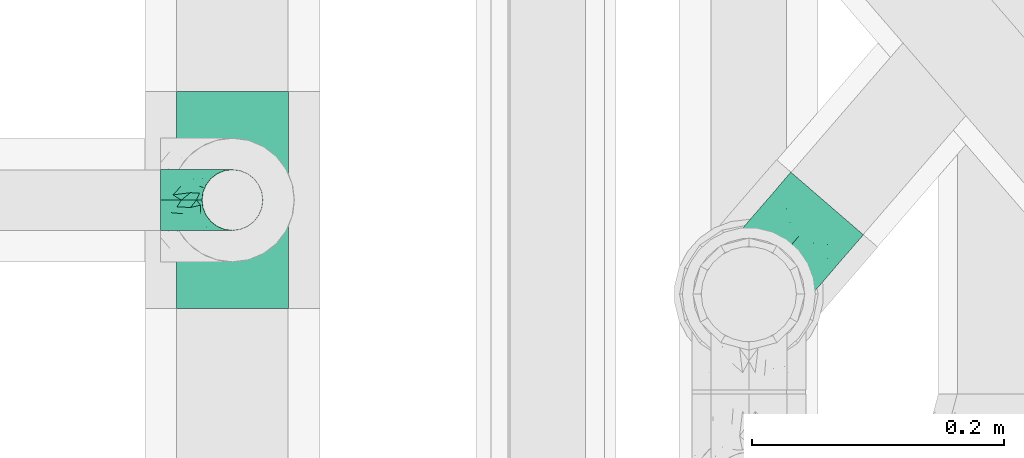
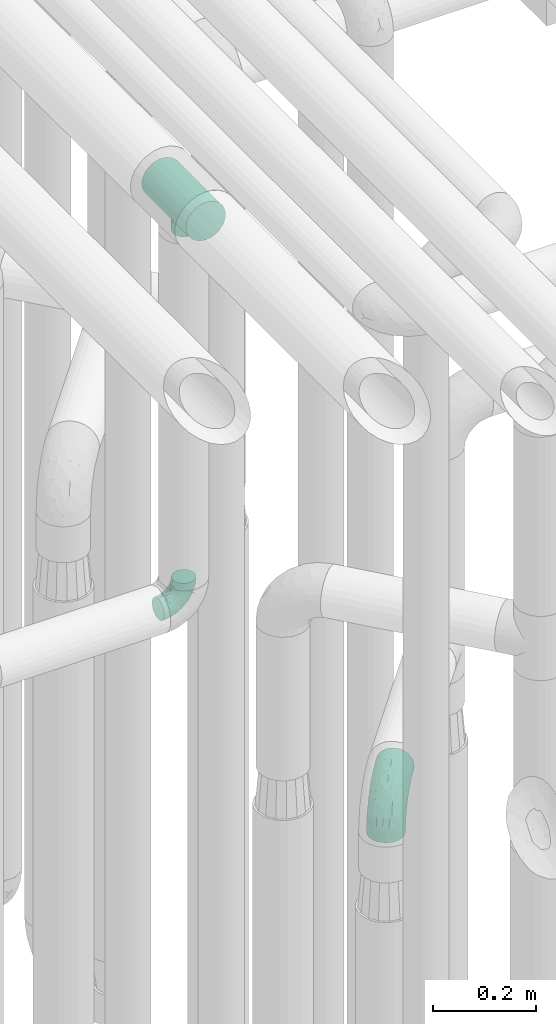
# One storey, part 607 of 827: 3 flow fittings.
"""IFC2X3 building model written with IfcOpenShell, lengths in millimetres."""

import ifcopenshell
import ifcopenshell.guid

model = None  # the IFC model being written
_history = None  # IfcOwnerHistory: only IFC2X3 demands one
_inside = {}  # id of a spatial element -> (the spatial element, [elements in it])
_under = {}  # id of a project, library or spatial element -> (it, [spatial elements below it])
_declared = {}  # id of a project -> (the project, [libraries it declares])
_typed = {}  # id of a type object -> (the type object, [elements of that type])
_made_of = {}  # id of a material, layer set ... -> (it, [elements and type objects made of it])


def new_model(schema):
    """Start an empty IFC model of exactly this schema.

    Asked for "IFC4X3", IfcOpenShell would pick the latest addendum, in which some entities
    have other attributes; the version numbers below select the first issue.
    IFC2X3 requires an IfcOwnerHistory on every rooted entity: one is made here for all.
    """
    global model, _history
    if schema == "IFC4X3":
        model = ifcopenshell.file(schema_version=(4, 3, 0, 0))
    else:
        model = ifcopenshell.file(schema=schema)
    _inside.clear()
    _under.clear()
    _declared.clear()
    _typed.clear()
    _made_of.clear()
    _history = None
    if model.schema == "IFC2X3":
        org = make("IfcOrganization", Name="unknown")
        user = make(
            "IfcPersonAndOrganization",
            ThePerson=make("IfcPerson", FamilyName="unknown"),
            TheOrganization=org,
        )
        app = make(
            "IfcApplication",
            ApplicationDeveloper=org,
            Version="unknown",
            ApplicationFullName="unknown",
            ApplicationIdentifier="unknown",
        )
        _history = make(
            "IfcOwnerHistory",
            OwningUser=user,
            OwningApplication=app,
            ChangeAction="ADDED",
            CreationDate=0,
        )
    return model


def make(cls, **values):
    """One entity of the class cls with the attributes given. An attribute that is None is left unset."""
    return model.create_entity(
        cls, **{name: value for name, value in values.items() if value is not None}
    )


def entity(cls, *values):
    """Any entity or typed value of the class cls, its attributes in the order of the schema. None: left unset."""
    e = model.create_entity(cls)
    for i, value in enumerate(values):
        if value is not None:
            e[i] = value
    return e


def rooted(cls, **values):
    """An entity with a GlobalId (a new one), such as an element, a storey or a relation."""
    return make(cls, GlobalId=ifcopenshell.guid.new(), OwnerHistory=_history, **values)


def si_unit(unit_type, name, prefix=None):
    """IfcSIUnit, for example si_unit("LENGTHUNIT", "METRE", prefix="MILLI")."""
    return make("IfcSIUnit", UnitType=unit_type, Prefix=prefix, Name=name)


def converted_unit(unit_type, name, factor, base, dimensions=None, offset=None):
    """IfcConversionBasedUnit, such as the inch: factor (a typed value) times the base unit."""
    return make(
        "IfcConversionBasedUnit"
        if offset is None
        else "IfcConversionBasedUnitWithOffset",
        ConversionOffset=offset,
        Dimensions=None
        if dimensions is None
        else entity("IfcDimensionalExponents", *dimensions),
        UnitType=unit_type,
        Name=name,
        ConversionFactor=make(
            "IfcMeasureWithUnit", ValueComponent=factor, UnitComponent=base
        ),
    )


def derived_unit(unit_type, elements):
    """IfcDerivedUnit: a product of units, each with its exponent."""
    return make(
        "IfcDerivedUnit",
        Elements=[
            make("IfcDerivedUnitElement", Unit=unit, Exponent=power)
            for unit, power in elements
        ],
        UnitType=unit_type,
    )


def assignment(units):
    """IfcUnitAssignment: the units of a project."""
    return None if units is None else make("IfcUnitAssignment", Units=units)


def point(xyz):
    """IfcCartesianPoint."""
    return None if xyz is None else make("IfcCartesianPoint", Coordinates=xyz)


def direction(xyz):
    """IfcDirection."""
    return None if xyz is None else make("IfcDirection", DirectionRatios=xyz)


def frame(location, z_axis=None, x_axis=None):
    """IfcAxis2Placement3D, a coordinate frame: its origin and axes. An axis left out is left unset."""
    return make(
        "IfcAxis2Placement3D",
        Location=point(location),
        Axis=direction(z_axis),
        RefDirection=direction(x_axis),
    )


def origin():
    """The frame at (0, 0, 0) with its axes left unset."""
    return frame((0.0, 0.0, 0.0))


def place(relative_to, where):
    """IfcLocalPlacement: puts the frame where relative to a parent placement (None: the world)."""
    return make(
        "IfcLocalPlacement", PlacementRelTo=relative_to, RelativePlacement=where
    )


def context(
    kind, dimensions, precision=None, world=None, true_north=None, identifier=None
):
    """IfcGeometricRepresentationContext, for example the 3D "Model" context."""
    return make(
        "IfcGeometricRepresentationContext",
        ContextIdentifier=identifier,
        ContextType=kind,
        CoordinateSpaceDimension=dimensions,
        Precision=precision,
        WorldCoordinateSystem=world,
        TrueNorth=true_north,
    )


def subcontext(parent, identifier, kind, view, scale=None):
    """IfcGeometricRepresentationSubContext, for example "Body" below "Model"."""
    return make(
        "IfcGeometricRepresentationSubContext",
        ContextIdentifier=identifier,
        ContextType=kind,
        ParentContext=parent,
        TargetScale=scale,
        TargetView=view,
    )


def project(units=None, contexts=None):
    """IfcProject with its units and contexts."""
    return rooted(
        "IfcProject",
        Name="project",
        RepresentationContexts=contexts,
        UnitsInContext=assignment(units),
    )


def spatial(cls, under=None, at=None, **own):
    """A site, building, storey or space (cls), placed at a placement, below another one or the project."""
    s = rooted(cls, ObjectPlacement=at, **own)
    if under is not None:
        _under.setdefault(under.id(), (under, []))[1].append(s)
    return s


def faces_of(points, faces, orient=None, outer=None):
    """IfcFace entities. A face is a list of loops; a loop is a list of indices into points, from 0.

    orient and outer hold one flag for each loop. By default every Orientation is true, the
    first loop of a face is its IfcFaceOuterBound and the others are IfcFaceBound.
    """
    made = []
    for i, loops in enumerate(faces):
        bounds = []
        for j, loop in enumerate(loops):
            is_outer = j == 0 if outer is None else outer[i][j]
            bounds.append(
                make(
                    "IfcFaceOuterBound" if is_outer else "IfcFaceBound",
                    Bound=make("IfcPolyLoop", Polygon=[points[k] for k in loop]),
                    Orientation=True if orient is None else orient[i][j],
                )
            )
        made.append(make("IfcFace", Bounds=bounds))
    return made


def faceted_brep(points, faces, orient=None, outer=None, voids=None):
    """IfcFacetedBrep: a solid bounded by flat faces; with voids (closed shells), ...WithVoids."""
    shared = [point(p) for p in points]
    hull = make("IfcClosedShell", CfsFaces=faces_of(shared, faces, orient, outer))
    if voids is None:
        return make("IfcFacetedBrep", Outer=hull)
    return make(
        "IfcFacetedBrepWithVoids",
        Outer=hull,
        Voids=[
            make(cls, CfsFaces=faces_of(shared, fs, o, b)) for cls, fs, o, b in voids
        ],
    )


def shape(context_of_items, identifier, shape_type, items):
    """IfcShapeRepresentation: the items that make up one representation, for example the "Body"."""
    return make(
        "IfcShapeRepresentation",
        ContextOfItems=context_of_items,
        RepresentationIdentifier=identifier,
        RepresentationType=shape_type,
        Items=items,
    )


def source(mapping_origin, context_of_items, identifier, shape_type, items):
    """IfcRepresentationMap: a shape defined once, which mapped items show again and again."""
    return make(
        "IfcRepresentationMap",
        MappingOrigin=mapping_origin,
        MappedRepresentation=shape(context_of_items, identifier, shape_type, items),
    )


def transform(
    local_origin,
    x_axis=None,
    y_axis=None,
    z_axis=None,
    scale=None,
    scale2=None,
    scale3=None,
    uniform=True,
):
    """IfcCartesianTransformationOperator3D, or its non-uniform kind. x_axis, y_axis, z_axis: its Axis1, 2, 3."""
    if uniform:
        return make(
            "IfcCartesianTransformationOperator3D",
            Axis1=direction(x_axis),
            Axis2=direction(y_axis),
            LocalOrigin=point(local_origin),
            Scale=scale,
            Axis3=direction(z_axis),
        )
    return make(
        "IfcCartesianTransformationOperator3DnonUniform",
        Axis1=direction(x_axis),
        Axis2=direction(y_axis),
        LocalOrigin=point(local_origin),
        Scale=scale,
        Axis3=direction(z_axis),
        Scale2=scale2,
        Scale3=scale3,
    )


def mapped(mapping_source, mapping_target):
    """IfcMappedItem: shows the shape of a source again, moved by a transform."""
    return make(
        "IfcMappedItem", MappingSource=mapping_source, MappingTarget=mapping_target
    )


def material(Name=None, Category=None):
    """IfcMaterial."""
    return make("IfcMaterial", Name=Name, Category=Category)


def made_of(thing, what):
    """Note that an element or type object is made of a material, layer set ...; save() writes the relation."""
    if what is not None:
        _made_of.setdefault(what.id(), (what, []))[1].append(thing)
    return thing


def type_object(cls, material=None, **own):
    """A type object (cls), such as IfcWallType, which elements share."""
    return made_of(rooted(cls, **own), material)


def type_shapes(of_type, sources):
    """Give a type object the sources (RepresentationMaps) that its elements show as mapped items."""
    of_type.RepresentationMaps = sources


def element(
    cls,
    number,
    at=None,
    inside=None,
    cuts=None,
    type_object=None,
    material=None,
    context=None,
    identifier="Body",
    shape_type=None,
    held_by="IfcProductDefinitionShape",
    body=None,
    shapes=None,
    **own,
):
    """One element of the class cls, such as IfcWall. Its Tag is "e" and its number.

    at: its placement. inside: the storey or other place that contains it. cuts: it is an
    opening in that element (IfcRelVoidsElement). A single representation is given by context,
    identifier, shape_type and body (its items); several are given by shapes. held_by: the class
    of the entity that holds the representations. save() writes the other relations.
    """
    e = rooted(cls, Tag="e%d" % number, ObjectPlacement=at, **own)
    if body is not None:
        shapes = [shape(context, identifier, shape_type, body)]
    if shapes is not None:
        e.Representation = make(held_by, Representations=shapes)
    if inside is not None:
        _inside.setdefault(inside.id(), (inside, []))[1].append(e)
    if cuts is not None:
        rooted(
            "IfcRelVoidsElement", RelatingBuildingElement=cuts, RelatedOpeningElement=e
        )
    if type_object is not None:
        _typed.setdefault(type_object.id(), (type_object, []))[1].append(e)
    return made_of(e, material)


def aggregate(whole, parts):
    """IfcRelAggregates: a whole, such as a stair, and the parts it consists of."""
    return rooted("IfcRelAggregates", RelatingObject=whole, RelatedObjects=parts)


def save(model, path):
    """Write the relations noted so far, then the file.

    IfcRelAggregates (storeys below a building ...), IfcRelContainedInSpatialStructure (elements
    in a storey), IfcRelDefinesByType, IfcRelAssociatesMaterial and IfcRelDeclares: one each for
    every whole, place, type object, material and project.
    """
    for whole, parts in _under.values():
        aggregate(whole, parts)
    for where, things in _inside.values():
        rooted(
            "IfcRelContainedInSpatialStructure",
            RelatedElements=things,
            RelatingStructure=where,
        )
    for kind, things in _typed.values():
        rooted("IfcRelDefinesByType", RelatedObjects=things, RelatingType=kind)
    for what, things in _made_of.values():
        rooted("IfcRelAssociatesMaterial", RelatedObjects=things, RelatingMaterial=what)
    for by, libraries in _declared.values():
        rooted("IfcRelDeclares", RelatingContext=by, RelatedDefinitions=libraries)
    model.write(path)


model = new_model("IFC2X3")

# Units and contexts
model_context = context("Model", 3, precision=0.01, world=origin(), true_north=direction((6.12303176911189e-17, 1.0)))
body_context = subcontext(model_context, "Body", "Model", "MODEL_VIEW")
ifc_project = project(units=[si_unit("LENGTHUNIT", "METRE", prefix="MILLI"), si_unit("AREAUNIT", "SQUARE_METRE"), si_unit("VOLUMEUNIT", "CUBIC_METRE"), converted_unit("PLANEANGLEUNIT", "DEGREE", entity("IfcRatioMeasure", 0.0174532925199433), si_unit("PLANEANGLEUNIT", "RADIAN"), dimensions=[0, 0, 0, 0, 0, 0, 0]), si_unit("MASSUNIT", "GRAM", prefix="KILO"), derived_unit("MASSDENSITYUNIT", [(si_unit("MASSUNIT", "GRAM", prefix="KILO"), 1), (si_unit("LENGTHUNIT", "METRE"), -3)]), derived_unit("MOMENTOFINERTIAUNIT", [(si_unit("LENGTHUNIT", "METRE"), 4)]), si_unit("TIMEUNIT", "SECOND"), si_unit("FREQUENCYUNIT", "HERTZ"), si_unit("THERMODYNAMICTEMPERATUREUNIT", "DEGREE_CELSIUS"), derived_unit("THERMALTRANSMITTANCEUNIT", [(si_unit("MASSUNIT", "GRAM", prefix="KILO"), 1), (si_unit("THERMODYNAMICTEMPERATUREUNIT", "KELVIN"), -1), (si_unit("TIMEUNIT", "SECOND"), -3)]), derived_unit("VOLUMETRICFLOWRATEUNIT", [(si_unit("LENGTHUNIT", "METRE"), 3), (si_unit("TIMEUNIT", "SECOND"), -1)]), derived_unit("MASSFLOWRATEUNIT", [(si_unit("MASSUNIT", "GRAM", prefix="KILO"), 1), (si_unit("TIMEUNIT", "SECOND"), -1)]), derived_unit("ROTATIONALFREQUENCYUNIT", [(si_unit("TIMEUNIT", "SECOND"), -1)]), si_unit("ELECTRICCURRENTUNIT", "AMPERE"), si_unit("ELECTRICVOLTAGEUNIT", "VOLT"), si_unit("POWERUNIT", "WATT"), si_unit("FORCEUNIT", "NEWTON", prefix="KILO"), si_unit("ILLUMINANCEUNIT", "LUX"), si_unit("LUMINOUSFLUXUNIT", "LUMEN"), si_unit("LUMINOUSINTENSITYUNIT", "CANDELA"), derived_unit("USERDEFINED", [(si_unit("MASSUNIT", "GRAM", prefix="KILO"), -1), (si_unit("LENGTHUNIT", "METRE"), -2), (si_unit("TIMEUNIT", "SECOND"), 3), (si_unit("LUMINOUSFLUXUNIT", "LUMEN"), 1)]), derived_unit("LINEARVELOCITYUNIT", [(si_unit("LENGTHUNIT", "METRE"), 1), (si_unit("TIMEUNIT", "SECOND"), -1)]), si_unit("PRESSUREUNIT", "PASCAL"), derived_unit("USERDEFINED", [(si_unit("LENGTHUNIT", "METRE"), -2), (si_unit("MASSUNIT", "GRAM", prefix="KILO"), 1), (si_unit("TIMEUNIT", "SECOND"), -2)]), derived_unit("LINEARFORCEUNIT", [(si_unit("MASSUNIT", "GRAM", prefix="KILO"), 1), (si_unit("LENGTHUNIT", "METRE"), 1), (si_unit("TIMEUNIT", "SECOND"), -2), (si_unit("LENGTHUNIT", "METRE"), -1)]), derived_unit("PLANARFORCEUNIT", [(si_unit("MASSUNIT", "GRAM", prefix="KILO"), 1), (si_unit("LENGTHUNIT", "METRE"), 1), (si_unit("TIMEUNIT", "SECOND"), -2), (si_unit("LENGTHUNIT", "METRE"), -2)])], contexts=[model_context])

# Site, building, storey
site_placement = place(None, origin())
site = spatial("IfcSite", under=ifc_project, at=site_placement, CompositionType="ELEMENT")
building_placement = place(site_placement, origin())
building = spatial("IfcBuilding", under=site, at=building_placement, CompositionType="ELEMENT")
storey_placement = place(building_placement, frame((0.0, 0.0, 28200.0)))
storey = spatial("IfcBuildingStorey", under=building, at=storey_placement, Name="08", CompositionType="ELEMENT", Elevation=28200.0)

# Flow fittings
ifc_material = material()
pipe_fitting_type_1 = type_object("IfcPipeFittingType", Name="ADSK_1", PredefinedType="NOTDEFINED", material=ifc_material)
shared_shape_1 = source(origin(), body_context, "Body", "Brep", [
    faceted_brep([(-57.0, 12.07, -20.91), (-57.0, 6.25, -23.33), (-57.0, 0.0, -24.15), (-57.0, -6.25, -23.33), (-57.0, -12.08, -20.91), (-57.0, -17.08, -17.08), (-57.0, -20.91, -12.08), (-57.0, -23.33, -6.25), (-57.0, -24.15, 0.0), (-57.0, -23.33, 6.25), (-57.0, -20.91, 12.07), (-57.0, -17.08, 17.08), (-57.0, -12.08, 20.91), (-57.0, -6.25, 23.33), (-57.0, 0.0, 24.15), (-57.0, 6.25, 23.33), (-57.0, 12.07, 20.91), (-57.0, 17.08, 17.08), (-57.0, 20.91, 12.07), (-57.0, 23.33, 6.25), (-57.0, 24.15, 0.0), (-57.0, 23.33, -6.25), (-57.0, 20.91, -12.08), (-57.0, 17.08, -17.08), (0.0, 57.0, -24.15), (-6.25, 57.0, -23.33), (-12.07, 57.0, -20.91), (-17.08, 57.0, -17.08), (-20.91, 57.0, -12.08), (-23.33, 57.0, -6.25), (-24.15, 57.0, 0.0), (-23.33, 57.0, 6.25), (-20.91, 57.0, 12.07), (-17.08, 57.0, 17.08), (-12.07, 57.0, 20.91), (-6.25, 57.0, 23.33), (0.0, 57.0, 24.15), (6.25, 57.0, 23.33), (12.08, 57.0, 20.91), (17.08, 57.0, 17.08), (20.91, 57.0, 12.07), (23.33, 57.0, 6.25), (24.15, 57.0, 0.0), (23.33, 57.0, -6.25), (20.91, 57.0, -12.08), (17.08, 57.0, -17.08), (12.08, 57.0, -20.91), (6.25, 57.0, -23.33), (14.9, 21.14, 6.17), (13.61, 24.64, 12.48), (6.23, 8.95, 8.98), (-41.47, -21.06, 0.0), (-41.92, -18.38, 13.72), (-24.64, -13.61, 12.48), (-37.37, -13.24, 18.15), (-6.8, -4.93, 8.18), (-21.76, -15.19, 6.22), (-12.78, -9.18, 0.0), (-37.73, -20.51, 7.75), (-7.38, 7.38, 20.24), (-23.37, -4.26, 20.42), (-11.9, -3.19, 15.86), (-42.14, -8.7, 21.82), (13.24, 37.37, 18.15), (9.33, 23.53, 16.85), (4.26, 23.37, 20.42), (2.77, 10.92, 15.55), (-29.46, 0.91, 23.52), (-44.13, 20.56, 15.69), (-39.25, 26.33, 10.88), (-49.02, 22.92, 9.96), (-34.58, 23.87, 17.15), (-15.8, 6.8, 22.81), (-8.67, 20.47, 23.88), (-18.12, 12.9, 24.08), (-48.29, 14.92, 19.65), (-44.06, -2.85, 23.78), (-9.23, 48.95, 22.58), (-3.78, 42.74, 24.07), (-40.34, 4.26, 24.09), (-44.02, 26.14, 5.46), (-44.04, 9.88, 22.74), (-4.95, 16.87, 22.52), (-2.75, 1.43, 12.5), (-25.48, 40.98, 10.71), (20.51, 37.73, 7.75), (18.38, 41.92, 13.72), (8.7, 42.14, 21.82), (-25.95, -17.97, 0.0), (2.85, 44.06, 23.78), (21.06, 41.47, 0.0), (17.97, 25.95, 0.0), (-24.04, -9.27, 17.13), (-33.26, 33.26, 5.86), (-28.55, 40.57, 0.0), (-40.57, 28.55, 0.0), (-25.29, 47.19, 4.06), (-27.01, 31.1, 16.77), (-15.7, 43.95, 19.9), (-20.27, 45.22, 15.61), (-30.53, 31.98, 12.64), (-11.28, 38.33, 22.92), (-9.97, 27.88, 24.09), (-20.15, 30.26, 21.25), (-31.25, 11.75, 23.64), (-28.75, 7.23, 24.15), (-29.53, 18.06, 22.27), (-28.44, 24.21, 20.02), (-37.55, 17.7, 20.26), (-15.88, 29.25, 22.99), (-20.82, 20.82, 23.44), (-0.91, 29.46, 23.52), (-13.5, -7.67, 12.04), (1.49, 1.56, 5.16), (8.86, 10.35, 4.59), (0.38, -0.38, 0.0), (9.18, 12.78, 0.0), (-37.37, -13.24, -18.15), (8.86, 10.35, -4.59), (-45.22, 20.27, -15.61), (-43.95, 15.7, -19.9), (-38.33, 11.28, -22.92), (-48.95, 9.23, -22.58), (-47.19, 25.29, -4.06), (-33.26, 33.26, -5.86), (18.38, 41.92, -13.72), (-30.26, 20.15, -21.25), (2.85, 44.06, -23.78), (-4.26, 40.34, -24.09), (-40.98, 25.48, -10.71), (-41.92, -18.38, -13.72), (9.25, 23.5, -16.92), (4.26, 23.37, -20.42), (13.24, 37.37, -18.15), (-37.73, -20.51, -7.75), (-11.75, 31.25, -23.64), (-7.23, 28.75, -24.15), (-12.9, 18.12, -24.08), (8.7, 42.14, -21.82), (-44.06, -2.85, -23.78), (-6.8, 15.8, -22.81), (-20.47, 8.67, -23.88), (-24.64, -13.61, -12.48), (-42.74, 3.78, -24.07), (-18.06, 29.53, -22.27), (-24.21, 28.44, -20.02), (-27.88, 9.97, -24.09), (-31.1, 27.01, -16.77), (-26.14, 44.02, -5.46), (14.9, 21.14, -6.17), (20.51, 37.73, -7.75), (-9.88, 44.04, -22.74), (-20.56, 44.13, -15.69), (-21.76, -15.19, -6.22), (-13.5, -7.67, -12.04), (-24.14, -9.76, -16.74), (-11.9, -3.19, -15.86), (-14.92, 48.29, -19.65), (-23.37, -4.26, -20.42), (-0.91, 29.46, -23.52), (-26.33, 39.25, -10.88), (-23.87, 34.58, -17.15), (-42.14, -8.7, -21.82), (-22.92, 49.02, -9.96), (13.61, 24.64, -12.48), (-31.98, 30.53, -12.64), (-16.87, 4.95, -22.52), (-17.7, 37.55, -20.26), (-29.25, 15.88, -22.99), (-20.82, 20.82, -23.44), (-29.46, 0.91, -23.52), (-7.38, 7.38, -20.24), (2.77, 10.92, -15.55), (6.23, 8.95, -8.98), (-6.8, -4.93, -8.18), (-2.81, 1.41, -12.54), (1.49, 1.56, -5.16)], [[[0, 1, 2, 3, 4, 5, 6, 7, 8, 9, 10, 11, 12, 13, 14, 15, 16, 17, 18, 19, 20, 21, 22, 23]], [[24, 25, 26, 27, 28, 29, 30, 31, 32, 33, 34, 35, 36, 37, 38, 39, 40, 41, 42, 43, 44, 45, 46, 47]], [[48, 49, 50]], [[9, 8, 51]], [[52, 53, 54]], [[55, 56, 57]], [[10, 58, 52]], [[9, 58, 10]], [[59, 60, 61]], [[54, 12, 11]], [[54, 62, 12]], [[63, 39, 38]], [[64, 65, 66]], [[62, 60, 67]], [[68, 69, 70]], [[71, 69, 68]], [[72, 73, 74]], [[16, 75, 17]], [[13, 76, 14]], [[35, 77, 78]], [[14, 79, 15]], [[17, 68, 18]], [[14, 76, 79]], [[20, 19, 80]], [[70, 19, 18]], [[81, 15, 79]], [[15, 81, 16]], [[73, 72, 82]], [[66, 83, 50]], [[32, 31, 84]], [[85, 86, 49]], [[63, 87, 65]], [[56, 58, 88]], [[36, 89, 37]], [[85, 41, 40]], [[36, 35, 78]], [[90, 41, 85]], [[40, 39, 86]], [[12, 62, 13]], [[86, 85, 40]], [[48, 85, 49]], [[85, 91, 90]], [[87, 38, 37]], [[92, 60, 54]], [[80, 69, 93]], [[93, 94, 95]], [[10, 52, 11]], [[94, 96, 30]], [[97, 98, 99]], [[80, 93, 95]], [[100, 97, 84]], [[99, 98, 33]], [[101, 102, 78]], [[103, 101, 98]], [[96, 31, 30]], [[77, 98, 101]], [[77, 35, 34]], [[34, 33, 98]], [[9, 51, 58]], [[87, 63, 38]], [[104, 105, 74]], [[106, 103, 107]], [[106, 81, 104]], [[75, 68, 17]], [[108, 107, 71]], [[33, 32, 99]], [[109, 103, 110]], [[101, 109, 102]], [[89, 78, 111]], [[53, 52, 58]], [[54, 11, 52]], [[60, 62, 54]], [[88, 58, 51]], [[76, 62, 67]], [[53, 112, 92]], [[60, 59, 72]], [[39, 63, 86]], [[49, 86, 63]], [[89, 87, 37]], [[42, 41, 90]], [[111, 82, 65]], [[111, 65, 87]], [[65, 59, 66]], [[104, 81, 79]], [[75, 81, 108]], [[32, 84, 99]], [[97, 99, 84]], [[98, 97, 103]], [[106, 107, 108]], [[74, 102, 110]], [[111, 78, 102]], [[74, 110, 104]], [[74, 67, 72]], [[61, 92, 112]], [[66, 59, 61]], [[56, 53, 58]], [[66, 50, 49]], [[61, 112, 83]], [[66, 49, 64]], [[78, 89, 36]], [[87, 89, 111]], [[62, 76, 13]], [[79, 76, 67]], [[100, 93, 69]], [[96, 93, 84]], [[55, 113, 50]], [[113, 114, 50]], [[104, 79, 105]], [[106, 104, 110]], [[20, 80, 95]], [[85, 48, 91]], [[115, 114, 113]], [[116, 91, 48]], [[70, 80, 19]], [[93, 96, 94]], [[84, 31, 96]], [[103, 106, 110]], [[81, 106, 108]], [[103, 97, 107]], [[71, 107, 97]], [[71, 97, 100]], [[108, 71, 68]], [[79, 67, 105]], [[67, 74, 105]], [[115, 113, 57]], [[112, 56, 55]], [[56, 88, 57]], [[60, 72, 67]], [[82, 72, 59]], [[65, 82, 59]], [[82, 111, 73]], [[111, 102, 73]], [[102, 74, 73]], [[81, 75, 16]], [[68, 75, 108]], [[68, 70, 18]], [[80, 70, 69]], [[98, 77, 34]], [[78, 77, 101]], [[93, 100, 84]], [[71, 100, 69]], [[102, 109, 110]], [[101, 103, 109]], [[53, 92, 54]], [[61, 60, 92]], [[56, 112, 53]], [[83, 112, 55]], [[50, 83, 55]], [[61, 83, 66]], [[49, 63, 64]], [[65, 64, 63]], [[57, 113, 55]], [[114, 115, 116]], [[116, 48, 114]], [[48, 50, 114]], [[117, 5, 4]], [[116, 115, 118]], [[119, 120, 23]], [[121, 122, 120]], [[95, 123, 20]], [[0, 23, 120]], [[124, 95, 94]], [[125, 45, 44]], [[121, 120, 126]], [[24, 127, 128]], [[22, 21, 129]], [[0, 122, 1]], [[5, 117, 130]], [[131, 132, 133]], [[134, 88, 51]], [[135, 136, 137]], [[6, 5, 130]], [[46, 138, 47]], [[139, 3, 2]], [[140, 141, 137]], [[6, 134, 7]], [[134, 130, 142]], [[143, 2, 1]], [[144, 126, 145]], [[121, 146, 143]], [[147, 120, 119]], [[94, 148, 124]], [[149, 150, 91]], [[30, 29, 148]], [[151, 25, 128]], [[27, 152, 28]], [[134, 153, 88]], [[154, 155, 156]], [[27, 26, 157]], [[151, 26, 25]], [[155, 158, 156]], [[24, 47, 127]], [[1, 122, 143]], [[138, 132, 159]], [[160, 152, 161]], [[24, 128, 25]], [[46, 133, 138]], [[162, 117, 4]], [[148, 160, 124]], [[152, 160, 163]], [[154, 142, 155]], [[45, 125, 133]], [[133, 46, 45]], [[125, 164, 133]], [[51, 7, 134]], [[42, 90, 43]], [[165, 147, 129]], [[153, 134, 142]], [[43, 150, 44]], [[162, 4, 3]], [[141, 140, 166]], [[117, 162, 158]], [[163, 29, 28]], [[43, 90, 150]], [[123, 21, 20]], [[144, 151, 135]], [[157, 152, 27]], [[167, 145, 161]], [[23, 22, 119]], [[168, 126, 169]], [[121, 168, 146]], [[139, 143, 170]], [[142, 130, 117]], [[8, 7, 51]], [[134, 6, 130]], [[139, 162, 3]], [[170, 166, 158]], [[170, 158, 162]], [[158, 171, 156]], [[44, 150, 125]], [[91, 150, 90]], [[164, 125, 150]], [[132, 138, 133]], [[127, 138, 159]], [[131, 164, 172]], [[132, 171, 140]], [[135, 151, 128]], [[157, 151, 167]], [[22, 129, 119]], [[147, 119, 129]], [[120, 147, 126]], [[144, 145, 167]], [[137, 146, 169]], [[170, 143, 146]], [[137, 169, 135]], [[137, 159, 140]], [[171, 172, 156]], [[173, 174, 175]], [[156, 175, 154]], [[174, 57, 153]], [[132, 172, 171]], [[172, 164, 173]], [[143, 139, 2]], [[162, 139, 170]], [[138, 127, 47]], [[128, 127, 159]], [[165, 124, 160]], [[123, 124, 129]], [[149, 173, 164]], [[176, 174, 173]], [[135, 128, 136]], [[144, 135, 169]], [[150, 149, 164]], [[176, 118, 115]], [[149, 91, 116]], [[30, 148, 94]], [[163, 148, 29]], [[124, 123, 95]], [[129, 21, 123]], [[126, 144, 169]], [[151, 144, 167]], [[126, 147, 145]], [[161, 145, 147]], [[161, 147, 165]], [[167, 161, 152]], [[128, 159, 136]], [[159, 137, 136]], [[154, 153, 142]], [[132, 140, 159]], [[174, 176, 57]], [[57, 88, 153]], [[166, 140, 171]], [[158, 166, 171]], [[166, 170, 141]], [[170, 146, 141]], [[146, 137, 141]], [[151, 157, 26]], [[152, 157, 167]], [[152, 163, 28]], [[148, 163, 160]], [[120, 122, 0]], [[143, 122, 121]], [[124, 165, 129]], [[161, 165, 160]], [[146, 168, 169]], [[121, 126, 168]], [[142, 117, 155]], [[158, 155, 117]], [[175, 156, 172]], [[153, 154, 174]], [[173, 175, 172]], [[174, 154, 175]], [[164, 131, 133]], [[172, 132, 131]], [[176, 173, 118]], [[57, 176, 115]], [[173, 149, 118]], [[149, 116, 118]]]),
])
type_shapes(pipe_fitting_type_1, [shared_shape_1])
flow_fitting_1_placement = place(storey_placement, frame((36220.03, 10156.2, 2600.0), z_axis=(0.0, -1.0, 0.0), x_axis=(1.0, 0.0, 0.0)))
element("IfcFlowFitting", 1, at=flow_fitting_1_placement, inside=storey, type_object=pipe_fitting_type_1, material=ifc_material, Name="ADSK_1", ObjectType="ADSK_1", context=body_context, shape_type="MappedRepresentation", body=[
    mapped(shared_shape_1, transform((0.0, 0.0, 0.0), scale=1.0)),
])
pipe_fitting_type_2 = type_object("IfcPipeFittingType", Name="ADSK_1", PredefinedType="NOTDEFINED", material=ifc_material)
shared_shape_2 = source(origin(), body_context, "Body", "Brep", [
    faceted_brep([(-95.0, 19.02, -32.95), (-95.0, 9.85, -36.75), (-95.0, 0.0, -38.05), (-95.0, -9.85, -36.75), (-95.0, -19.03, -32.95), (-95.0, -26.91, -26.91), (-95.0, -32.95, -19.03), (-95.0, -36.75, -9.85), (-95.0, -38.05, 0.0), (-95.0, -36.75, 9.85), (-95.0, -32.95, 19.02), (-95.0, -26.91, 26.91), (-95.0, -19.03, 32.95), (-95.0, -9.85, 36.75), (-95.0, 0.0, 38.05), (-95.0, 9.85, 36.75), (-95.0, 19.02, 32.95), (-95.0, 26.91, 26.91), (-95.0, 32.95, 19.02), (-95.0, 36.75, 9.85), (-95.0, 38.05, 0.0), (-95.0, 36.75, -9.85), (-95.0, 32.95, -19.03), (-95.0, 26.91, -26.91), (0.0, 95.0, -38.05), (-9.85, 95.0, -36.75), (-19.02, 95.0, -32.95), (-26.91, 95.0, -26.91), (-32.95, 95.0, -19.03), (-36.75, 95.0, -9.85), (-38.05, 95.0, 0.0), (-36.75, 95.0, 9.85), (-32.95, 95.0, 19.02), (-26.91, 95.0, 26.91), (-19.02, 95.0, 32.95), (-9.85, 95.0, 36.75), (0.0, 95.0, 38.05), (9.85, 95.0, 36.75), (19.03, 95.0, 32.95), (26.91, 95.0, 26.91), (32.95, 95.0, 19.02), (36.75, 95.0, 9.85), (38.05, 95.0, 0.0), (36.75, 95.0, -9.85), (32.95, 95.0, -19.03), (26.91, 95.0, -26.91), (19.03, 95.0, -32.95), (9.85, 95.0, -36.75), (-7.99, -4.96, 6.3), (-0.92, 0.92, 0.0), (4.62, 8.1, 8.01), (-76.19, -35.57, 0.0), (-64.32, -32.32, 12.43), (20.51, 62.45, 28.68), (-60.56, -33.52, 0.0), (-70.4, -13.47, 34.42), (-39.61, -5.88, 32.32), (-49.6, 2.07, 37.1), (-70.34, -28.81, 21.71), (14.64, 40.81, 26.5), (5.88, 39.61, 32.32), (3.59, 20.77, 25.31), (-40.45, 68.06, 16.75), (-62.45, -20.51, 28.68), (-44.52, -26.87, 0.0), (-28.47, -20.22, 0.0), (-26.43, -17.83, 8.75), (-76.1, 39.63, 10.76), (-72.74, 37.58, 18.19), (-60.35, 46.18, 14.61), (-13.4, 13.4, 32.12), (-20.77, -3.59, 25.31), (-14.66, 81.47, 35.56), (-6.22, 71.26, 37.92), (-57.5, 42.48, 22.79), (-15.0, 34.74, 37.7), (-27.1, 12.08, 36.05), (-9.2, 28.81, 35.63), (-79.98, 23.7, 30.95), (-73.68, -4.3, 37.48), (-30.74, 21.67, 37.97), (-62.36, 47.59, 6.79), (-72.71, 32.83, 24.69), (-67.42, 7.02, 37.95), (-32.13, 75.27, 24.51), (-43.46, 51.47, 26.26), (-24.98, 73.15, 31.29), (20.59, 41.28, 19.85), (7.79, 16.09, 15.86), (-73.21, 42.39, 0.0), (-54.73, 54.73, 0.0), (-73.44, 15.79, 35.79), (-5.94, 4.32, 20.43), (28.81, 70.34, 21.71), (32.32, 64.32, 12.43), (-53.59, 26.2, 35.09), (-52.02, 19.31, 37.21), (21.38, 33.53, 10.34), (26.87, 44.52, 0.0), (-48.28, 12.14, 38.05), (4.3, 73.68, 37.48), (-44.08, -25.52, 12.79), (-41.28, -20.59, 19.85), (35.57, 76.19, 0.0), (-47.26, 54.3, 20.18), (-47.4, 61.99, 8.58), (-42.39, 73.21, 0.0), (-39.67, 78.86, 7.21), (-45.69, 36.84, 33.11), (-32.83, 50.13, 33.35), (13.47, 70.4, 34.42), (-18.25, 63.73, 36.07), (-40.63, -13.75, 27.22), (-16.63, 46.37, 37.95), (-53.47, 38.79, 28.59), (-26.07, 48.54, 36.15), (-34.51, 34.51, 36.86), (-2.07, 49.6, 37.1), (-22.79, -10.49, 19.23), (-61.73, 28.67, 31.87), (9.65, 14.7, 0.0), (20.22, 28.47, 0.0), (33.52, 60.56, 0.0), (-11.42, -5.44, 13.25), (-14.7, -9.65, 0.0), (-81.47, 14.66, -35.56), (-62.45, -20.51, -28.68), (-71.26, 6.22, -37.92), (-75.27, 32.13, -24.51), (-73.15, 24.98, -31.29), (13.47, 70.4, -34.42), (5.88, 39.61, -32.32), (-2.07, 49.6, -37.1), (-78.86, 39.67, -7.21), (-70.4, -13.47, -34.42), (-39.61, -5.88, -32.32), (-61.99, 47.4, -8.58), (32.32, 64.32, -12.43), (28.81, 70.34, -21.71), (-63.73, 18.25, -36.07), (-50.13, 32.83, -33.35), (4.3, 73.68, -37.48), (-7.02, 67.42, -37.95), (-39.63, 76.1, -10.76), (-46.18, 60.35, -14.61), (-47.59, 62.36, -6.79), (-64.32, -32.32, -12.43), (-26.2, 53.59, -35.09), (-15.79, 73.44, -35.79), (-19.31, 52.02, -37.21), (-37.58, 72.74, -18.19), (-70.34, -28.81, -21.71), (-42.48, 57.5, -22.79), (-38.79, 53.47, -28.59), (-51.47, 43.46, -26.26), (-32.83, 72.71, -24.69), (-46.37, 16.63, -37.95), (-73.68, -4.3, -37.48), (-41.28, -20.59, -19.85), (-44.08, -25.52, -12.79), (13.75, 40.63, -27.22), (20.51, 62.45, -28.68), (-68.06, 40.45, -16.75), (-54.3, 47.26, -20.18), (-12.14, 48.28, -38.05), (-21.67, 30.74, -37.97), (-36.84, 45.69, -33.11), (-11.42, -5.44, -13.25), (7.79, 16.09, -15.86), (4.62, 8.1, -8.01), (-23.7, 79.98, -30.95), (-26.43, -17.83, -8.75), (-7.99, -4.96, -6.3), (-40.81, -14.64, -26.5), (-20.77, -3.59, -25.31), (-34.74, 15.0, -37.7), (-12.08, 27.1, -36.05), (-28.81, 9.2, -35.63), (-22.79, -10.49, -19.23), (21.38, 33.53, -10.34), (20.59, 41.28, -19.85), (-48.54, 26.07, -36.15), (-49.6, 2.07, -37.1), (-13.4, 13.4, -32.12), (3.59, 20.77, -25.31), (-28.67, 61.73, -31.87), (-34.51, 34.51, -36.86), (-5.94, 4.32, -20.43)], [[[0, 1, 2, 3, 4, 5, 6, 7, 8, 9, 10, 11, 12, 13, 14, 15, 16, 17, 18, 19, 20, 21, 22, 23]], [[24, 25, 26, 27, 28, 29, 30, 31, 32, 33, 34, 35, 36, 37, 38, 39, 40, 41, 42, 43, 44, 45, 46, 47]], [[48, 49, 50]], [[51, 52, 9]], [[53, 39, 38]], [[9, 52, 10]], [[54, 52, 51]], [[55, 56, 57]], [[11, 10, 58]], [[59, 60, 61]], [[32, 31, 62]], [[63, 12, 11]], [[63, 55, 12]], [[64, 65, 66]], [[67, 68, 69]], [[70, 56, 71]], [[35, 72, 73]], [[69, 68, 74]], [[75, 76, 77]], [[16, 78, 17]], [[13, 79, 14]], [[76, 75, 80]], [[67, 69, 81]], [[18, 17, 82]], [[14, 79, 83]], [[20, 19, 67]], [[84, 85, 86]], [[87, 61, 88]], [[89, 81, 90]], [[18, 82, 68]], [[15, 91, 16]], [[14, 83, 15]], [[71, 92, 61]], [[17, 78, 82]], [[93, 87, 94]], [[95, 91, 96]], [[97, 98, 94]], [[86, 72, 34]], [[96, 99, 80]], [[37, 36, 100]], [[40, 39, 93]], [[40, 94, 41]], [[64, 66, 101]], [[93, 94, 40]], [[58, 102, 63]], [[94, 103, 41]], [[94, 87, 97]], [[104, 69, 74]], [[34, 33, 86]], [[105, 69, 104]], [[52, 58, 10]], [[106, 107, 30]], [[108, 109, 85]], [[105, 106, 90]], [[53, 110, 60]], [[86, 111, 72]], [[86, 109, 111]], [[33, 84, 86]], [[12, 55, 13]], [[112, 56, 63]], [[110, 38, 37]], [[34, 72, 35]], [[36, 35, 73]], [[111, 113, 73]], [[105, 107, 106]], [[110, 53, 38]], [[74, 114, 85]], [[91, 15, 83]], [[105, 90, 81]], [[107, 62, 31]], [[33, 32, 84]], [[115, 109, 116]], [[111, 115, 113]], [[100, 73, 117]], [[56, 55, 63]], [[79, 55, 57]], [[102, 118, 112]], [[56, 70, 76]], [[100, 110, 37]], [[117, 77, 60]], [[117, 60, 110]], [[60, 70, 61]], [[58, 52, 101]], [[63, 11, 58]], [[39, 53, 93]], [[87, 93, 53]], [[96, 91, 83]], [[78, 91, 119]], [[32, 62, 84]], [[84, 62, 104]], [[86, 85, 109]], [[85, 114, 108]], [[80, 113, 116]], [[117, 73, 113]], [[80, 116, 96]], [[80, 57, 76]], [[71, 112, 118]], [[61, 87, 59]], [[62, 107, 105]], [[97, 120, 121]], [[70, 71, 61]], [[71, 118, 92]], [[73, 100, 36]], [[110, 100, 117]], [[55, 79, 13]], [[83, 79, 57]], [[96, 83, 99]], [[116, 108, 95]], [[50, 97, 88]], [[97, 87, 88]], [[50, 49, 120]], [[122, 94, 98]], [[89, 20, 67]], [[105, 81, 69]], [[89, 67, 81]], [[68, 19, 18]], [[68, 67, 19]], [[74, 68, 82]], [[114, 82, 119]], [[74, 85, 104]], [[82, 114, 74]], [[114, 119, 108]], [[95, 108, 119]], [[116, 109, 108]], [[123, 48, 50]], [[97, 50, 120]], [[123, 50, 88]], [[91, 95, 119]], [[116, 95, 96]], [[84, 104, 85]], [[104, 62, 105]], [[83, 57, 99]], [[57, 80, 99]], [[66, 48, 123]], [[66, 124, 48]], [[118, 66, 123]], [[124, 66, 65]], [[66, 118, 101]], [[54, 64, 52]], [[124, 49, 48]], [[30, 107, 31]], [[91, 78, 16]], [[82, 78, 119]], [[56, 76, 57]], [[77, 76, 70]], [[60, 77, 70]], [[77, 117, 75]], [[117, 113, 75]], [[113, 80, 75]], [[9, 8, 51]], [[103, 94, 122]], [[103, 42, 41]], [[73, 72, 111]], [[113, 115, 116]], [[111, 109, 115]], [[102, 112, 63]], [[71, 56, 112]], [[118, 102, 101]], [[92, 123, 88]], [[123, 92, 118]], [[61, 92, 88]], [[87, 53, 59]], [[60, 59, 53]], [[97, 121, 98]], [[58, 101, 102]], [[64, 101, 52]], [[125, 1, 0]], [[126, 5, 4]], [[2, 1, 127]], [[1, 125, 127]], [[128, 129, 23]], [[130, 131, 132]], [[89, 133, 20]], [[126, 134, 135]], [[136, 89, 90]], [[137, 138, 44]], [[139, 129, 140]], [[24, 141, 142]], [[143, 144, 145]], [[125, 129, 139]], [[6, 146, 7]], [[147, 148, 149]], [[146, 51, 7]], [[143, 150, 144]], [[146, 6, 151]], [[152, 153, 154]], [[126, 4, 134]], [[0, 23, 129]], [[28, 155, 150]], [[43, 42, 103]], [[54, 146, 64]], [[139, 156, 127]], [[157, 3, 2]], [[151, 158, 159]], [[160, 131, 161]], [[22, 21, 162]], [[136, 144, 163]], [[149, 164, 165]], [[24, 142, 25]], [[166, 140, 154]], [[154, 129, 128]], [[143, 30, 29]], [[167, 168, 169]], [[155, 28, 27]], [[26, 170, 27]], [[171, 167, 172]], [[26, 25, 148]], [[27, 170, 155]], [[173, 135, 174]], [[144, 150, 152]], [[175, 176, 177]], [[24, 47, 141]], [[45, 161, 46]], [[148, 25, 142]], [[176, 175, 165]], [[64, 159, 171]], [[138, 45, 44]], [[130, 46, 161]], [[137, 44, 43]], [[178, 159, 158]], [[137, 103, 122]], [[163, 144, 152]], [[136, 133, 89]], [[103, 137, 43]], [[6, 5, 151]], [[178, 158, 173]], [[134, 4, 3]], [[178, 173, 174]], [[137, 98, 179]], [[145, 90, 106]], [[138, 180, 161]], [[46, 130, 47]], [[136, 90, 145]], [[133, 162, 21]], [[23, 22, 128]], [[139, 140, 181]], [[139, 181, 156]], [[157, 127, 182]], [[157, 134, 3]], [[182, 177, 135]], [[182, 135, 134]], [[135, 183, 174]], [[131, 130, 161]], [[141, 130, 132]], [[160, 180, 184]], [[131, 183, 176]], [[5, 126, 151]], [[158, 151, 126]], [[180, 138, 137]], [[161, 45, 138]], [[149, 148, 142]], [[170, 148, 185]], [[22, 162, 128]], [[128, 162, 163]], [[129, 154, 140]], [[154, 153, 166]], [[165, 156, 186]], [[182, 127, 156]], [[165, 186, 149]], [[165, 132, 176]], [[131, 184, 183]], [[187, 167, 178]], [[184, 168, 187]], [[167, 169, 172]], [[184, 180, 168]], [[174, 183, 184]], [[127, 157, 2]], [[134, 157, 182]], [[130, 141, 47]], [[142, 141, 132]], [[149, 142, 164]], [[186, 166, 147]], [[180, 179, 168]], [[169, 179, 120]], [[137, 179, 180]], [[179, 121, 120]], [[106, 30, 143]], [[136, 145, 144]], [[106, 143, 145]], [[150, 29, 28]], [[150, 143, 29]], [[152, 150, 155]], [[153, 155, 185]], [[152, 154, 163]], [[155, 153, 152]], [[153, 185, 166]], [[147, 166, 185]], [[186, 140, 166]], [[169, 120, 49]], [[169, 49, 172]], [[179, 169, 168]], [[148, 147, 185]], [[186, 147, 149]], [[128, 163, 154]], [[163, 162, 136]], [[142, 132, 164]], [[132, 165, 164]], [[171, 124, 65]], [[124, 171, 172]], [[64, 146, 159]], [[171, 159, 178]], [[171, 65, 64]], [[172, 49, 124]], [[162, 133, 136]], [[20, 133, 21]], [[148, 170, 26]], [[155, 170, 185]], [[131, 176, 132]], [[177, 176, 183]], [[135, 177, 183]], [[177, 182, 175]], [[182, 156, 175]], [[156, 165, 175]], [[51, 146, 54]], [[51, 8, 7]], [[129, 125, 0]], [[127, 125, 139]], [[140, 186, 181]], [[156, 181, 186]], [[158, 126, 173]], [[135, 173, 126]], [[187, 178, 174]], [[171, 178, 167]], [[184, 187, 174]], [[167, 187, 168]], [[180, 160, 161]], [[184, 131, 160]], [[98, 137, 122]], [[98, 121, 179]], [[151, 159, 146]]]),
])
type_shapes(pipe_fitting_type_2, [shared_shape_2])
flow_fitting_2_placement = place(storey_placement, frame((36629.64, 10081.59, 2050.0), z_axis=(-0.756825266247892, 0.653617255256322, 0.0), x_axis=(0.0, 0.0, 1.0)))
element("IfcFlowFitting", 2, at=flow_fitting_2_placement, inside=storey, type_object=pipe_fitting_type_2, material=ifc_material, Name="ADSK_1", ObjectType="ADSK_1", context=body_context, shape_type="MappedRepresentation", body=[
    mapped(shared_shape_2, transform((0.0, 0.0, 0.0), scale=1.0)),
])
pipe_fitting_type_3 = type_object("IfcPipeFittingType", Name="ADSK_1", PredefinedType="NOTDEFINED", material=ifc_material)
shared_shape_3 = source(origin(), body_context, "Body", "Brep", [
    faceted_brep([(-86.0, 22.22, -38.49), (-86.0, 11.5, -42.94), (-86.0, 0.0, -44.45), (-86.0, -11.5, -42.94), (-86.0, -22.23, -38.49), (-86.0, -31.43, -31.43), (-86.0, -38.49, -22.23), (-86.0, -42.94, -11.5), (-86.0, -44.45, 0.0), (-86.0, -42.94, 11.5), (-86.0, -38.49, 22.22), (-86.0, -31.43, 31.43), (-86.0, -22.23, 38.49), (-86.0, -11.5, 42.94), (-86.0, 0.0, 44.45), (-86.0, 11.5, 42.94), (-86.0, 22.22, 38.49), (-86.0, 31.43, 31.43), (-86.0, 38.49, 22.22), (-86.0, 42.94, 11.5), (-86.0, 44.45, 0.0), (-86.0, 42.94, -11.5), (-86.0, 38.49, -22.23), (-86.0, 31.43, -31.43), (86.0, 0.0, -44.45), (86.0, 11.5, -42.94), (86.0, 22.22, -38.49), (86.0, 31.43, -31.43), (86.0, 38.49, -22.23), (86.0, 42.94, -11.5), (86.0, 44.45, 0.0), (86.0, 42.94, 11.5), (86.0, 38.49, 22.22), (86.0, 31.43, 31.43), (86.0, 22.22, 38.49), (86.0, 11.5, 42.94), (86.0, 0.0, 44.45), (86.0, -11.5, 42.94), (86.0, -22.23, 38.49), (86.0, -31.43, 31.43), (86.0, -38.49, 22.22), (86.0, -42.94, 11.5), (86.0, -44.45, 0.0), (86.0, -42.94, -11.5), (86.0, -38.49, -22.23), (86.0, -31.43, -31.43), (86.0, -22.23, -38.49), (86.0, -11.5, -42.94), (22.65, -43.65, 8.39), (23.4, -44.05, 4.19), (24.15, -44.45, 0.0), (18.45, -41.63, 15.58), (4.27, -37.56, 23.77), (12.15, -39.25, 20.87), (8.21, -38.4, 22.32), (-24.15, -44.45, 0.0), (-23.4, -44.05, 4.19), (-22.65, -43.65, 8.38), (-18.46, -41.63, 15.57), (-12.16, -39.25, 20.87), (-8.22, -38.4, 22.32), (-4.28, -37.56, 23.77), (0.0, -37.56, 23.77), (4.27, -37.56, -23.77), (12.15, -39.25, -20.87), (8.21, -38.4, -22.32), (18.45, -41.63, -15.58), (22.65, -43.65, -8.39), (23.4, -44.05, -4.19), (-4.28, -37.56, -23.77), (-8.22, -38.4, -22.32), (-12.16, -39.25, -20.87), (-18.46, -41.63, -15.57), (0.0, -37.56, -23.77), (-22.65, -43.65, -8.38), (-23.4, -44.05, -4.19), (0.0, -73.0, -24.15), (6.25, -73.0, -23.33), (12.08, -73.0, -20.91), (17.08, -73.0, -17.08), (20.91, -73.0, -12.08), (23.33, -73.0, -6.25), (24.15, -73.0, 0.0), (23.33, -73.0, 6.25), (20.91, -73.0, 12.07), (17.08, -73.0, 17.08), (12.08, -73.0, 20.91), (6.25, -73.0, 23.33), (0.0, -73.0, 24.15), (-6.25, -73.0, 23.33), (-12.07, -73.0, 20.91), (-17.08, -73.0, 17.08), (-20.91, -73.0, 12.07), (-23.33, -73.0, 6.25), (-24.15, -73.0, 0.0), (-23.33, -73.0, -6.25), (-20.91, -73.0, -12.08), (-17.08, -73.0, -17.08), (-12.07, -73.0, -20.91), (-6.25, -73.0, -23.33)], [[[0, 1, 2, 3, 4, 5, 6, 7, 8, 9, 10, 11, 12, 13, 14, 15, 16, 17, 18, 19, 20, 21, 22, 23]], [[24, 25, 26, 27, 28, 29, 30, 31, 32, 33, 34, 35, 36, 37, 38, 39, 40, 41, 42, 43, 44, 45, 46, 47]], [[42, 41, 48]], [[42, 48, 49, 50]], [[41, 51, 48]], [[40, 39, 52]], [[53, 51, 40]], [[40, 52, 54, 53]], [[39, 11, 52]], [[40, 51, 41]], [[8, 55, 56, 57]], [[9, 8, 57]], [[57, 58, 9]], [[10, 59, 60, 61]], [[59, 10, 58]], [[10, 61, 11]], [[58, 10, 9]], [[11, 61, 62, 52]], [[39, 38, 12, 11]], [[14, 13, 37, 36]], [[13, 12, 38, 37]], [[15, 14, 36, 35]], [[32, 31, 19, 18]], [[17, 16, 34, 33]], [[18, 17, 33, 32]], [[35, 34, 16, 15]], [[20, 19, 31, 30]], [[29, 28, 22, 21]], [[28, 27, 23, 22]], [[30, 29, 21, 20]], [[24, 47, 3, 2]], [[1, 0, 26, 25]], [[2, 1, 25, 24]], [[27, 26, 0, 23]], [[4, 3, 47, 46]], [[46, 45, 5, 4]], [[45, 44, 63]], [[44, 64, 65, 63]], [[44, 66, 64]], [[45, 63, 5]], [[43, 42, 67]], [[67, 66, 43]], [[42, 50, 68, 67]], [[43, 66, 44]], [[6, 69, 70, 71]], [[6, 5, 69]], [[71, 72, 6]], [[5, 63, 73, 69]], [[72, 74, 7]], [[74, 8, 7]], [[8, 74, 75, 55]], [[72, 7, 6]], [[76, 77, 78, 79, 80, 81, 82, 83, 84, 85, 86, 87, 88, 89, 90, 91, 92, 93, 94, 95, 96, 97, 98, 99]], [[93, 56, 94]], [[88, 61, 89]], [[60, 90, 89]], [[60, 59, 90]], [[86, 54, 87]], [[93, 57, 56]], [[49, 82, 50]], [[57, 93, 92]], [[56, 55, 94]], [[57, 92, 58]], [[90, 59, 91]], [[89, 61, 60]], [[91, 59, 58]], [[91, 58, 92]], [[88, 52, 62, 61]], [[86, 53, 54]], [[85, 53, 86]], [[48, 84, 83]], [[85, 84, 51]], [[52, 88, 87]], [[54, 52, 87]], [[53, 85, 51]], [[51, 84, 48]], [[82, 49, 83]], [[49, 48, 83]], [[81, 68, 82]], [[79, 66, 80]], [[65, 64, 78]], [[81, 67, 68]], [[80, 67, 81]], [[64, 79, 78]], [[68, 50, 82]], [[67, 80, 66]], [[77, 63, 65]], [[64, 66, 79]], [[76, 69, 73, 63]], [[98, 70, 99]], [[75, 94, 55]], [[98, 71, 70]], [[76, 63, 77]], [[75, 74, 95]], [[97, 71, 98]], [[74, 96, 95]], [[97, 96, 72]], [[69, 76, 99]], [[70, 69, 99]], [[71, 97, 72]], [[72, 96, 74]], [[94, 75, 95]], [[65, 78, 77]]]),
])
type_shapes(pipe_fitting_type_3, [shared_shape_3])
flow_fitting_3_placement = place(storey_placement, frame((36220.03, 10156.2, 3550.0), z_axis=(1.0, 0.0, 0.0), x_axis=(0.0, 1.0, -9.1155891697908e-08)))
element("IfcFlowFitting", 3, at=flow_fitting_3_placement, inside=storey, type_object=pipe_fitting_type_3, material=ifc_material, Name="ADSK_1", ObjectType="ADSK_1", context=body_context, shape_type="MappedRepresentation", body=[
    mapped(shared_shape_3, transform((0.0, 0.0, 0.0), scale=1.0)),
])

save(model, "model.ifc")
